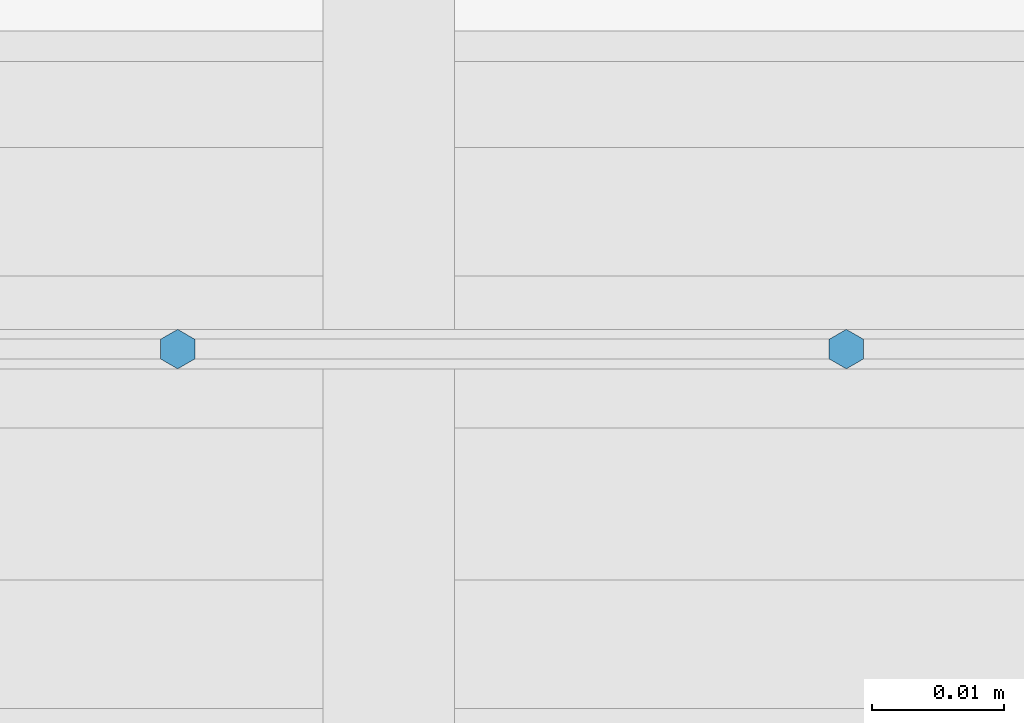
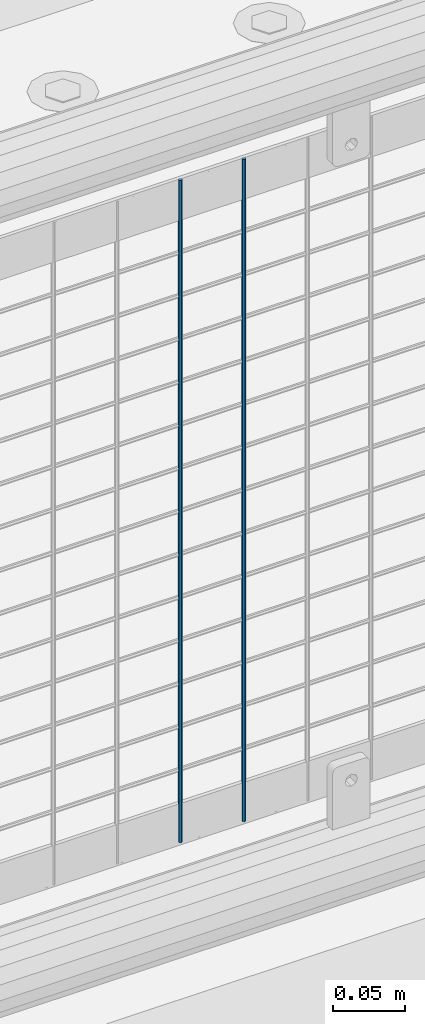
# One storey, part 95 of 242: 2 columns.
"""IFC2X3 building model written with IfcOpenShell, lengths in millimetres."""

from ifc_helpers import new_model, si_unit, frame, origin_with_axes, place, context, subcontext, project, spatial, faceted_brep, material, type_object, element, save


model = new_model("IFC2X3")

# Units and contexts
model_context = context("Model", 3, precision=1e-05, world=origin_with_axes())
body_context = subcontext(model_context, "Body", "Model", "MODEL_VIEW")
ifc_project = project(units=[si_unit("LENGTHUNIT", "METRE", prefix="MILLI"), si_unit("AREAUNIT", "SQUARE_METRE"), si_unit("VOLUMEUNIT", "CUBIC_METRE"), si_unit("MASSUNIT", "GRAM", prefix="KILO"), si_unit("TIMEUNIT", "SECOND"), si_unit("PLANEANGLEUNIT", "RADIAN"), si_unit("SOLIDANGLEUNIT", "STERADIAN"), si_unit("THERMODYNAMICTEMPERATUREUNIT", "DEGREE_CELSIUS"), si_unit("LUMINOUSINTENSITYUNIT", "LUMEN")], contexts=[model_context])

# Site, building, storey
site_placement = place(None, origin_with_axes())
site = spatial("IfcSite", under=ifc_project, at=site_placement, CompositionType="ELEMENT")
building_placement = place(site_placement, origin_with_axes())
building = spatial("IfcBuilding", under=site, at=building_placement, Name="Standard", CompositionType="ELEMENT")
storey_placement = place(building_placement, origin_with_axes())
storey = spatial("IfcBuildingStorey", under=building, at=storey_placement, Name="Undefined", CompositionType="ELEMENT", Elevation=0.0)

# Columns
ifc_material = material(Name="Misc_Undefined")
column_type = type_object("IfcColumnType", Name="D3", PredefinedType="NOTDEFINED")
for number, where, z_axis, x_axis in (
    (1, (-28380.242, -19329.5, 353.02), (-1.0, 0.0, 0.0), (0.0, 0.0, 1.0)),
    (2, (-28431.035, -19329.5, 353.02), (-1.0, 0.0, 0.0), (0.0, 0.0, 1.0)),
):
    element("IfcColumn", number, at=place(storey_placement, frame(where, z_axis=z_axis, x_axis=x_axis)), inside=storey, type_object=column_type, material=ifc_material, ObjectType="D3", context=body_context, shape_type="Brep", body=[
        faceted_brep([(0.0, -1.50000000000364, 0.0), (-3.63797880709171e-12, -0.750000000003638, -1.29903810567669), (560.0, -0.75, -1.29903810567703), (560.0, -1.5, 0.0), (0.0, 0.749999999996362, -1.29903810567669), (560.0, 0.75, -1.29903810567703), (-3.63797880709171e-12, 1.49999999999636, 0.0), (560.0, 1.5, 0.0), (0.0, 0.749999999996362, 1.29903810567669), (560.0, 0.75, 1.29903810567703), (-3.63797880709171e-12, -0.750000000003638, 1.29903810567669), (560.0, -0.75, 1.29903810567703)], [[[0, 1, 2, 3]], [[1, 4, 5, 2]], [[4, 6, 7, 5]], [[6, 8, 9, 7]], [[8, 10, 11, 9]], [[10, 0, 3, 11]], [[5, 7, 9, 11, 3, 2]], [[10, 8, 6, 4, 1, 0]]]),
    ])

save(model, "model.ifc")
